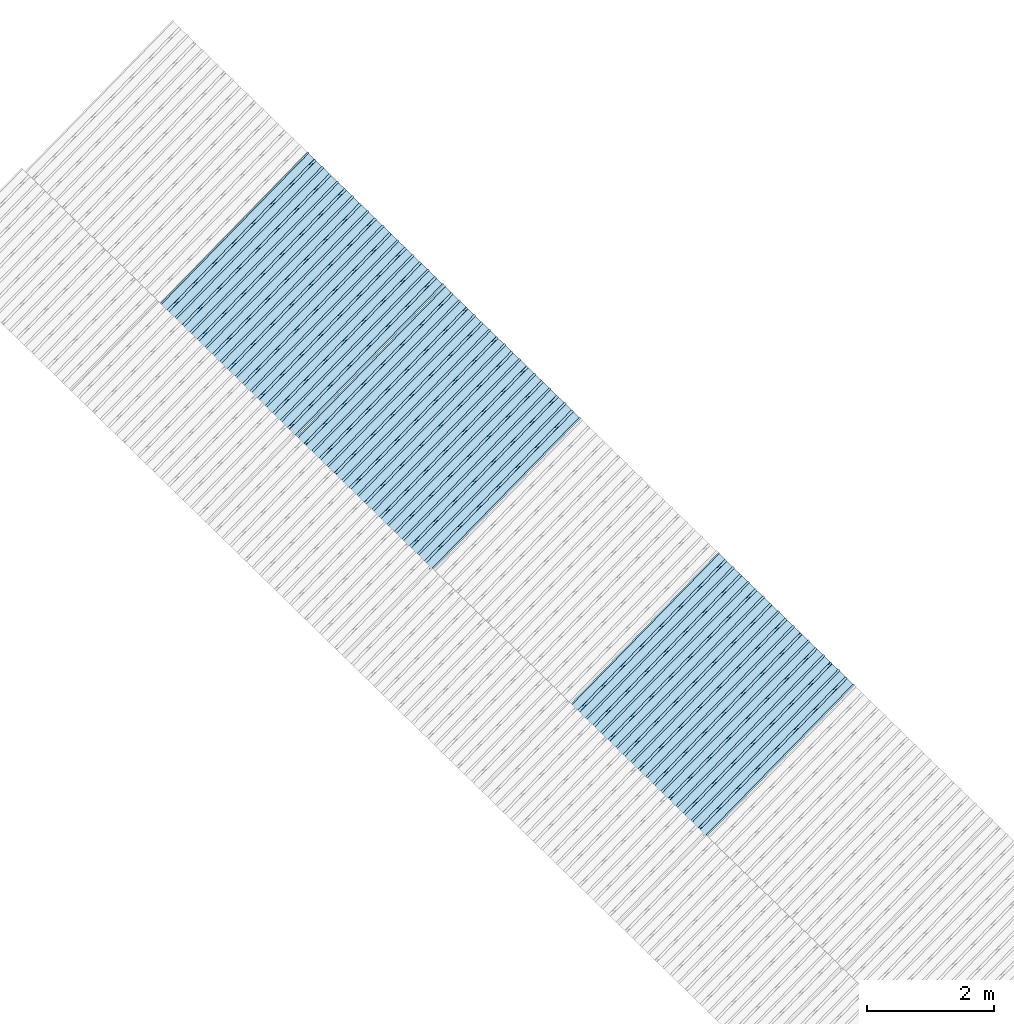
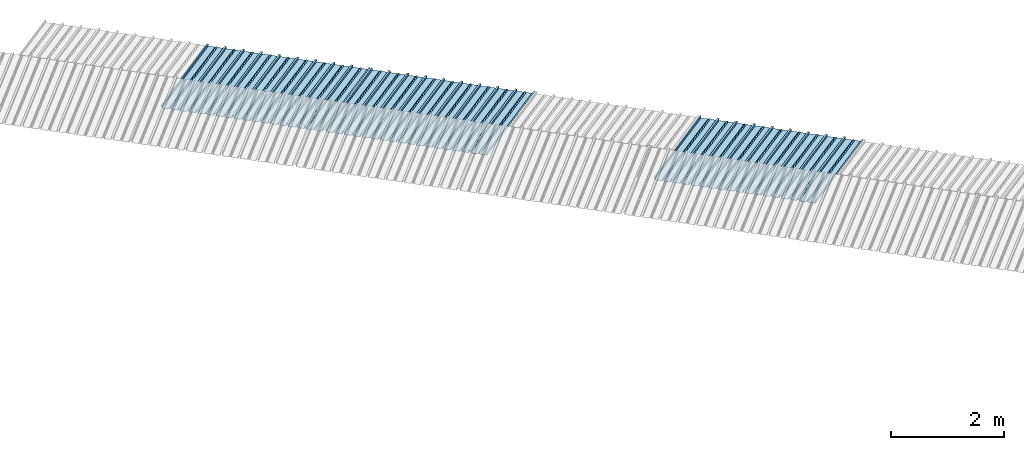
# One storey, part 7 of 8: 3 plates, 1 element without a shape of its own.
"""IFC4 building model written with IfcOpenShell, lengths in metres."""

from ifc_helpers import new_model, entity, si_unit, converted_unit, direction, frame, origin, place, context, subcontext, project, spatial, line, arc, indexed_curve, outline, extrude, source, transform, mapped, material, type_object, type_shapes, element, aggregate, save


model = new_model("IFC4")

# Units and contexts
model_context = context("Model", 3, precision=1e-05, world=origin(), true_north=direction((6.123233995736766e-17, 1.0)))
body_context = subcontext(model_context, "Body", "Model", "MODEL_VIEW")
ifc_project = project(units=[si_unit("LENGTHUNIT", "METRE"), si_unit("AREAUNIT", "SQUARE_METRE"), si_unit("VOLUMEUNIT", "CUBIC_METRE"), converted_unit("PLANEANGLEUNIT", "DEGREE", entity("IfcPlaneAngleMeasure", 0.017453292519943278), si_unit("PLANEANGLEUNIT", "RADIAN"), dimensions=[0, 0, 0, 0, 0, 0, 0])], contexts=[model_context])

# Site, building, storey
site_placement = place(None, frame((0.0, 0.0, 0.0), z_axis=(0.0, 0.0, 1.0), x_axis=(0.7160934825303189, -0.6980043870045516, 0.0)))
site = spatial("IfcSite", under=ifc_project, at=site_placement, CompositionType="ELEMENT")
building_placement = place(site_placement, origin())
building = spatial("IfcBuilding", under=site, at=building_placement, CompositionType="ELEMENT")
storey_placement = place(building_placement, frame((0.0, 0.0, -1.24)))
storey = spatial("IfcBuildingStorey", under=building, at=storey_placement, Name="Livello 5", CompositionType="ELEMENT", Elevation=-1.24)

# Roof, plates
curtain_wall_type = type_object("IfcCurtainWallType", Name="Vetrata Copertura 2", PredefinedType="NOTDEFINED")
roof_placement = place(storey_placement, frame((0.0, 0.0, 1.24)))
roof = element("IfcRoof", 1, at=roof_placement, inside=storey, type_object=curtain_wall_type, Name="Vetrata Copertura 2", ObjectType="Vetrata Copertura 2", PredefinedType="SHED_ROOF")
ifc_material = material(Name="Default")
plate_type_1 = type_object("IfcPlateType", Name="Pannello copertura:Pannello copertura", PredefinedType="CURTAIN_PANEL", material=ifc_material)
shared_shape_1 = source(origin(), body_context, "Body", "SweptSolid", [
    extrude(outline(indexed_curve([(1.339910560042256, -0.015785714285718594), (1.4699105600422562, -0.015785714285719003), (1.4699105600422562, 0.024214285714281004), (1.494919197675959, 0.02421428571428092), (1.494919197675959, 0.027214285714280917), (1.466910560042256, 0.027214285714281014), (1.466910560042256, -0.012785714285718995), (1.3417510978483753, -0.012785714285718492), (1.3199105600422556, 4.9134324369942785e-05), (1.2980700222361363, -0.012785714285718328), (1.1729105600422558, -0.01278571428571804), (1.1729105600422558, 0.02721428571428197), (1.136910560042256, 0.027214285714282097), (1.136910560042256, -0.012785714285717937), (1.0117510978483748, -0.01278571428571754), (0.9899105600422554, 4.913432437100935e-05), (0.968070022236136, -0.01278571428571726), (0.8429105600422558, -0.012785714285716971), (0.842910560042256, 0.027214285714283023), (0.8069105600422554, 0.027214285714283144), (0.8069105600422554, -0.01278571428571687), (0.6817510978483748, -0.012785714285716475), (0.6599105600422555, 4.9134324372075926e-05), (0.6380700222361361, -0.012785714285716196), (0.5129105600422553, -0.012785714285715915), (0.5129105600422554, 0.027214285714284105), (0.47691056004225557, 0.027214285714284227), (0.47691056004225557, -0.012785714285715804), (0.3517510978483749, -0.012785714285715427), (0.32991056004225544, 4.9134324373142496e-05), (0.3080700222361361, -0.012785714285715127), (0.18291056004225528, -0.012785714285714848), (0.18291056004225553, 0.027214285714285157), (0.1469105600422553, 0.02721428571428528), (0.14691056004225533, -0.012785714285714738), (0.021751097848374697, -0.01278571428571434), (-8.943995774469983e-05, 4.913432437420907e-05), (-0.021929977763864118, -0.01278571428571406), (-0.1470894399577447, -0.012785714285713783), (-0.14708943995774473, 0.02721428571428624), (-0.18308943995774493, 0.027214285714286364), (-0.1830894399577449, -0.012785714285713672), (-0.30824890215162537, -0.012785714285713215), (-0.33008943995774487, 4.9134324375275644e-05), (-0.3519299777638641, -0.012785714285712995), (-0.47708943995774494, -0.012785714285712714), (-0.4770894399577447, 0.02721428571428729), (-0.5130894399577449, 0.02721428571428741), (-0.5130894399577449, -0.012785714285712603), (-0.6382489021516256, -0.012785714285712207), (-0.6600894399577448, 4.9134324376342214e-05), (-0.6819299777638644, -0.012785714285711926), (-0.8070894399577453, -0.012785714285711647), (-0.807089439957745, 0.027214285714288373), (-0.843089439957745, 0.027214285714288494), (-0.8430894399577447, -0.012785714285711538), (-0.968248902151626, -0.012785714285711083), (-0.9900894399577453, 4.9134324377408785e-05), (-1.0119299777638646, -0.012785714285710861), (-1.1370894399577456, -0.012785714285710582), (-1.1370894399577451, 0.02721428571428942), (-1.1730894399577452, 0.027214285714289545), (-1.1730894399577454, -0.012785714285710473), (-1.2982489021516257, -0.012785714285710093), (-1.3200894399577452, 4.9134324378475355e-05), (-1.3419299777638647, -0.012785714285709794), (-1.4670894399577457, -0.012785714285709513), (-1.4670894399577454, 0.027214285714290503), (-1.490089439957745, 0.027214285714290586), (-1.490089439957745, 0.024214285714290556), (-1.4700894399577447, 0.02421428571429049), (-1.4700894399577449, -0.015785714285709514), (-1.3400894399577452, -0.015785714285709924), (-1.3200894399577452, -0.0029508656756215236), (-1.3000894399577452, -0.015785714285710063), (-1.170089439957745, -0.015785714285710472), (-1.1700894399577453, 0.024214285714289543), (-1.140089439957745, 0.02421428571428944), (-1.1400894399577455, -0.015785714285710583), (-1.0100894399577454, -0.015785714285710992), (-0.9900894399577453, -0.00295086567562259), (-0.9700894399577453, -0.015785714285711128), (-0.8400894399577448, -0.01578571428571154), (-0.8400894399577451, 0.024214285714288453), (-0.8100894399577452, 0.024214285714288356), (-0.8100894399577452, -0.015785714285711648), (-0.6800894399577451, -0.015785714285712012), (-0.6600894399577448, -0.0029508656756236573), (-0.6400894399577448, -0.015785714285712196), (-0.5100894399577451, -0.015785714285712606), (-0.5100894399577451, 0.024214285714287406), (-0.4800894399577449, 0.024214285714287305), (-0.4800894399577449, -0.015785714285712713), (-0.350089439957745, -0.01578571428571316), (-0.33008943995774487, -0.0029508656756247237), (-0.31008943995774485, -0.01578571428571326), (-0.1800894399577448, -0.015785714285713674), (-0.1800894399577448, 0.024214285714286323), (-0.1500894399577446, 0.02421428571428622), (-0.15008943995774485, -0.015785714285713782), (-0.020089439957744877, -0.015785714285714264), (-8.943995774473269e-05, -0.00295086567562579), (0.01991056004225521, -0.015785714285714323), (0.14991056004225545, -0.01578571428571474), (0.14991056004225542, 0.024214285714285272), (0.17991056004225567, 0.02421428571428517), (0.1799105600422554, -0.01578571428571485), (0.30991056004225526, -0.01578571428571532), (0.32991056004225544, -0.0029508656756268565), (0.3499105600422554, -0.015785714285715395), (0.47991056004225535, -0.015785714285715804), (0.47991056004225535, 0.02421428571428419), (0.5099105600422553, 0.02421428571428409), (0.5099105600422552, -0.015785714285715916), (0.6399105600422554, -0.015785714285716325), (0.6599105600422555, -0.002950865675627923), (0.6799105600422555, -0.01578571428571646), (0.8099105600422557, -0.015785714285716873), (0.8099105600422557, 0.02421428571428314), (0.8399105600422555, 0.02421428571428304), (0.8399105600422554, -0.015785714285716974), (0.9699105600422554, -0.015785714285717393), (0.9899105600422554, -0.0029508656756289894), (1.0099105600422555, -0.01578571428571753), (1.1399105600422557, -0.015785714285717938), (1.1399105600422557, 0.024214285714282077), (1.169910560042256, 0.024214285714281972), (1.1699105600422557, -0.01578571428571804), (1.2999105600422558, -0.01578571428571846), (1.3199105600422558, -0.0029508656756300567)], segments=[line(1, 2, 3, 4, 5, 6, 7, 8), arc(8, 9, 10), line(10, 11, 12, 13, 14, 15), arc(15, 16, 17), line(17, 18, 19, 20, 21, 22), arc(22, 23, 24), line(24, 25, 26, 27, 28, 29), arc(29, 30, 31), line(31, 32, 33, 34, 35, 36), arc(36, 37, 38), line(38, 39, 40, 41, 42, 43), arc(43, 44, 45), line(45, 46, 47, 48, 49, 50), arc(50, 51, 52), line(52, 53, 54, 55, 56, 57), arc(57, 58, 59), line(59, 60, 61, 62, 63, 64), arc(64, 65, 66), line(66, 67, 68, 69, 70, 71, 72, 73), arc(73, 74, 75), line(75, 76, 77, 78, 79, 80), arc(80, 81, 82), line(82, 83, 84, 85, 86, 87), arc(87, 88, 89), line(89, 90, 91, 92, 93, 94), arc(94, 95, 96), line(96, 97, 98, 99, 100, 101), arc(101, 102, 103), line(103, 104, 105, 106, 107, 108), arc(108, 109, 110), line(110, 111, 112, 113, 114, 115), arc(115, 116, 117), line(117, 118, 119, 120, 121, 122), arc(122, 123, 124), line(124, 125, 126, 127, 128, 129), arc(129, 130, 1)], self_intersect=False)), frame((8.080232403624576e-05, -0.015785714285719014, 0.0), z_axis=(0.0, 0.0, -1.0), x_axis=(1.0, 0.0, 0.0)), (0.0, 0.0, -1.0), 3.472878469300717),
])
type_shapes(plate_type_1, [shared_shape_1])
plate_1_placement = place(roof_placement, frame((-23.174876898450716, -4.997561216564662, -1.6240000000000003), z_axis=(0.0, 0.9632563788424056, -0.26858359707810914), x_axis=(1.0, 0.0, 0.0)))
plate_1 = element("IfcPlate", 2, at=plate_1_placement, type_object=plate_type_1, material=ifc_material, Name="Pannello copertura:Pannello copertura", ObjectType="Pannello copertura:Pannello copertura", PredefinedType="CURTAIN_PANEL", context=body_context, shape_type="MappedRepresentation", body=[
    mapped(shared_shape_1, transform((0.0, 0.0, 0.0), scale=1.0)),
])
plate_type_2 = type_object("IfcPlateType", Name="Pannello copertura:Pannello copertura", PredefinedType="CURTAIN_PANEL", material=ifc_material)
shared_shape_2 = source(origin(), body_context, "Body", "SweptSolid", [
    extrude(outline(indexed_curve([(1.339910560042256, -0.015785714285718594), (1.4699105600422562, -0.015785714285719003), (1.4699105600422562, 0.024214285714281004), (1.494919197675959, 0.02421428571428092), (1.494919197675959, 0.027214285714280917), (1.466910560042256, 0.027214285714281014), (1.466910560042256, -0.012785714285718995), (1.3417510978483753, -0.012785714285718492), (1.3199105600422556, 4.9134324369942785e-05), (1.2980700222361363, -0.012785714285718328), (1.1729105600422558, -0.01278571428571804), (1.1729105600422558, 0.02721428571428197), (1.136910560042256, 0.027214285714282097), (1.136910560042256, -0.012785714285717937), (1.0117510978483748, -0.01278571428571754), (0.9899105600422554, 4.913432437100935e-05), (0.968070022236136, -0.01278571428571726), (0.8429105600422558, -0.012785714285716971), (0.842910560042256, 0.027214285714283023), (0.8069105600422554, 0.027214285714283144), (0.8069105600422554, -0.01278571428571687), (0.6817510978483748, -0.012785714285716475), (0.6599105600422555, 4.9134324372075926e-05), (0.6380700222361361, -0.012785714285716196), (0.5129105600422553, -0.012785714285715915), (0.5129105600422554, 0.027214285714284105), (0.47691056004225557, 0.027214285714284227), (0.47691056004225557, -0.012785714285715804), (0.3517510978483749, -0.012785714285715427), (0.32991056004225544, 4.9134324373142496e-05), (0.3080700222361361, -0.012785714285715127), (0.18291056004225528, -0.012785714285714848), (0.18291056004225553, 0.027214285714285157), (0.1469105600422553, 0.02721428571428528), (0.14691056004225533, -0.012785714285714738), (0.021751097848374697, -0.01278571428571434), (-8.943995774469983e-05, 4.913432437420907e-05), (-0.021929977763864118, -0.01278571428571406), (-0.1470894399577447, -0.012785714285713783), (-0.14708943995774473, 0.02721428571428624), (-0.18308943995774493, 0.027214285714286364), (-0.1830894399577449, -0.012785714285713672), (-0.30824890215162537, -0.012785714285713215), (-0.33008943995774487, 4.9134324375275644e-05), (-0.3519299777638641, -0.012785714285712995), (-0.47708943995774494, -0.012785714285712714), (-0.4770894399577447, 0.02721428571428729), (-0.5130894399577449, 0.02721428571428741), (-0.5130894399577449, -0.012785714285712603), (-0.6382489021516256, -0.012785714285712207), (-0.6600894399577448, 4.9134324376342214e-05), (-0.6819299777638644, -0.012785714285711926), (-0.8070894399577453, -0.012785714285711647), (-0.807089439957745, 0.027214285714288373), (-0.843089439957745, 0.027214285714288494), (-0.8430894399577447, -0.012785714285711538), (-0.968248902151626, -0.012785714285711083), (-0.9900894399577453, 4.9134324377408785e-05), (-1.0119299777638646, -0.012785714285710861), (-1.1370894399577456, -0.012785714285710582), (-1.1370894399577451, 0.02721428571428942), (-1.1730894399577452, 0.027214285714289545), (-1.1730894399577454, -0.012785714285710473), (-1.2982489021516257, -0.012785714285710093), (-1.3200894399577452, 4.9134324378475355e-05), (-1.3419299777638647, -0.012785714285709794), (-1.4670894399577457, -0.012785714285709513), (-1.4670894399577454, 0.027214285714290503), (-1.490089439957745, 0.027214285714290586), (-1.490089439957745, 0.024214285714290556), (-1.4700894399577447, 0.02421428571429049), (-1.4700894399577449, -0.015785714285709514), (-1.3400894399577452, -0.015785714285709924), (-1.3200894399577452, -0.0029508656756215236), (-1.3000894399577452, -0.015785714285710063), (-1.170089439957745, -0.015785714285710472), (-1.1700894399577453, 0.024214285714289543), (-1.140089439957745, 0.02421428571428944), (-1.1400894399577455, -0.015785714285710583), (-1.0100894399577454, -0.015785714285710992), (-0.9900894399577453, -0.00295086567562259), (-0.9700894399577453, -0.015785714285711128), (-0.8400894399577448, -0.01578571428571154), (-0.8400894399577451, 0.024214285714288453), (-0.8100894399577452, 0.024214285714288356), (-0.8100894399577452, -0.015785714285711648), (-0.6800894399577451, -0.015785714285712012), (-0.6600894399577448, -0.0029508656756236573), (-0.6400894399577448, -0.015785714285712196), (-0.5100894399577451, -0.015785714285712606), (-0.5100894399577451, 0.024214285714287406), (-0.4800894399577449, 0.024214285714287305), (-0.4800894399577449, -0.015785714285712713), (-0.350089439957745, -0.01578571428571316), (-0.33008943995774487, -0.0029508656756247237), (-0.31008943995774485, -0.01578571428571326), (-0.1800894399577448, -0.015785714285713674), (-0.1800894399577448, 0.024214285714286323), (-0.1500894399577446, 0.02421428571428622), (-0.15008943995774485, -0.015785714285713782), (-0.020089439957744877, -0.015785714285714264), (-8.943995774473269e-05, -0.00295086567562579), (0.01991056004225521, -0.015785714285714323), (0.14991056004225545, -0.01578571428571474), (0.14991056004225542, 0.024214285714285272), (0.17991056004225567, 0.02421428571428517), (0.1799105600422554, -0.01578571428571485), (0.30991056004225526, -0.01578571428571532), (0.32991056004225544, -0.0029508656756268565), (0.3499105600422554, -0.015785714285715395), (0.47991056004225535, -0.015785714285715804), (0.47991056004225535, 0.02421428571428419), (0.5099105600422553, 0.02421428571428409), (0.5099105600422552, -0.015785714285715916), (0.6399105600422554, -0.015785714285716325), (0.6599105600422555, -0.002950865675627923), (0.6799105600422555, -0.01578571428571646), (0.8099105600422557, -0.015785714285716873), (0.8099105600422557, 0.02421428571428314), (0.8399105600422555, 0.02421428571428304), (0.8399105600422554, -0.015785714285716974), (0.9699105600422554, -0.015785714285717393), (0.9899105600422554, -0.0029508656756289894), (1.0099105600422555, -0.01578571428571753), (1.1399105600422557, -0.015785714285717938), (1.1399105600422557, 0.024214285714282077), (1.169910560042256, 0.024214285714281972), (1.1699105600422557, -0.01578571428571804), (1.2999105600422558, -0.01578571428571846), (1.3199105600422558, -0.0029508656756300567)], segments=[line(1, 2, 3, 4, 5, 6, 7, 8), arc(8, 9, 10), line(10, 11, 12, 13, 14, 15), arc(15, 16, 17), line(17, 18, 19, 20, 21, 22), arc(22, 23, 24), line(24, 25, 26, 27, 28, 29), arc(29, 30, 31), line(31, 32, 33, 34, 35, 36), arc(36, 37, 38), line(38, 39, 40, 41, 42, 43), arc(43, 44, 45), line(45, 46, 47, 48, 49, 50), arc(50, 51, 52), line(52, 53, 54, 55, 56, 57), arc(57, 58, 59), line(59, 60, 61, 62, 63, 64), arc(64, 65, 66), line(66, 67, 68, 69, 70, 71, 72, 73), arc(73, 74, 75), line(75, 76, 77, 78, 79, 80), arc(80, 81, 82), line(82, 83, 84, 85, 86, 87), arc(87, 88, 89), line(89, 90, 91, 92, 93, 94), arc(94, 95, 96), line(96, 97, 98, 99, 100, 101), arc(101, 102, 103), line(103, 104, 105, 106, 107, 108), arc(108, 109, 110), line(110, 111, 112, 113, 114, 115), arc(115, 116, 117), line(117, 118, 119, 120, 121, 122), arc(122, 123, 124), line(124, 125, 126, 127, 128, 129), arc(129, 130, 1)], self_intersect=False)), frame((8.080232403624576e-05, -0.015785714285719014, 0.0), z_axis=(0.0, 0.0, -1.0), x_axis=(1.0, 0.0, 0.0)), (0.0, 0.0, -1.0), 3.472878469300717),
])
type_shapes(plate_type_2, [shared_shape_2])
plate_2_placement = place(roof_placement, frame((-20.174871829776173, -4.997561216564662, -1.6240000000000003), z_axis=(0.0, 0.9632563788424056, -0.26858359707810914), x_axis=(1.0, 0.0, 0.0)))
plate_2 = element("IfcPlate", 3, at=plate_2_placement, type_object=plate_type_2, material=ifc_material, Name="Pannello copertura:Pannello copertura", ObjectType="Pannello copertura:Pannello copertura", PredefinedType="CURTAIN_PANEL", context=body_context, shape_type="MappedRepresentation", body=[
    mapped(shared_shape_2, transform((0.0, 0.0, 0.0), scale=1.0)),
])
plate_type_3 = type_object("IfcPlateType", Name="Pannello copertura:Pannello copertura", PredefinedType="CURTAIN_PANEL", material=ifc_material)
shared_shape_3 = source(origin(), body_context, "Body", "SweptSolid", [
    extrude(outline(indexed_curve([(1.339910560042256, -0.015785714285718594), (1.4699105600422562, -0.015785714285719003), (1.4699105600422562, 0.024214285714281004), (1.494919197675959, 0.02421428571428092), (1.494919197675959, 0.027214285714280917), (1.466910560042256, 0.027214285714281014), (1.466910560042256, -0.012785714285718995), (1.3417510978483753, -0.012785714285718492), (1.3199105600422556, 4.9134324369942785e-05), (1.2980700222361363, -0.012785714285718328), (1.1729105600422558, -0.01278571428571804), (1.1729105600422558, 0.02721428571428197), (1.136910560042256, 0.027214285714282097), (1.136910560042256, -0.012785714285717937), (1.0117510978483748, -0.01278571428571754), (0.9899105600422554, 4.913432437100935e-05), (0.968070022236136, -0.01278571428571726), (0.8429105600422558, -0.012785714285716971), (0.842910560042256, 0.027214285714283023), (0.8069105600422554, 0.027214285714283144), (0.8069105600422554, -0.01278571428571687), (0.6817510978483748, -0.012785714285716475), (0.6599105600422555, 4.9134324372075926e-05), (0.6380700222361361, -0.012785714285716196), (0.5129105600422553, -0.012785714285715915), (0.5129105600422554, 0.027214285714284105), (0.47691056004225557, 0.027214285714284227), (0.47691056004225557, -0.012785714285715804), (0.3517510978483749, -0.012785714285715427), (0.32991056004225544, 4.9134324373142496e-05), (0.3080700222361361, -0.012785714285715127), (0.18291056004225528, -0.012785714285714848), (0.18291056004225553, 0.027214285714285157), (0.1469105600422553, 0.02721428571428528), (0.14691056004225533, -0.012785714285714738), (0.021751097848374697, -0.01278571428571434), (-8.943995774469983e-05, 4.913432437420907e-05), (-0.021929977763864118, -0.01278571428571406), (-0.1470894399577447, -0.012785714285713783), (-0.14708943995774473, 0.02721428571428624), (-0.18308943995774493, 0.027214285714286364), (-0.1830894399577449, -0.012785714285713672), (-0.30824890215162537, -0.012785714285713215), (-0.33008943995774487, 4.9134324375275644e-05), (-0.3519299777638641, -0.012785714285712995), (-0.47708943995774494, -0.012785714285712714), (-0.4770894399577447, 0.02721428571428729), (-0.5130894399577449, 0.02721428571428741), (-0.5130894399577449, -0.012785714285712603), (-0.6382489021516256, -0.012785714285712207), (-0.6600894399577448, 4.9134324376342214e-05), (-0.6819299777638644, -0.012785714285711926), (-0.8070894399577453, -0.012785714285711647), (-0.807089439957745, 0.027214285714288373), (-0.843089439957745, 0.027214285714288494), (-0.8430894399577447, -0.012785714285711538), (-0.968248902151626, -0.012785714285711083), (-0.9900894399577453, 4.9134324377408785e-05), (-1.0119299777638646, -0.012785714285710861), (-1.1370894399577456, -0.012785714285710582), (-1.1370894399577451, 0.02721428571428942), (-1.1730894399577452, 0.027214285714289545), (-1.1730894399577454, -0.012785714285710473), (-1.2982489021516257, -0.012785714285710093), (-1.3200894399577452, 4.9134324378475355e-05), (-1.3419299777638647, -0.012785714285709794), (-1.4670894399577457, -0.012785714285709513), (-1.4670894399577454, 0.027214285714290503), (-1.490089439957745, 0.027214285714290586), (-1.490089439957745, 0.024214285714290556), (-1.4700894399577447, 0.02421428571429049), (-1.4700894399577449, -0.015785714285709514), (-1.3400894399577452, -0.015785714285709924), (-1.3200894399577452, -0.0029508656756215236), (-1.3000894399577452, -0.015785714285710063), (-1.170089439957745, -0.015785714285710472), (-1.1700894399577453, 0.024214285714289543), (-1.140089439957745, 0.02421428571428944), (-1.1400894399577455, -0.015785714285710583), (-1.0100894399577454, -0.015785714285710992), (-0.9900894399577453, -0.00295086567562259), (-0.9700894399577453, -0.015785714285711128), (-0.8400894399577448, -0.01578571428571154), (-0.8400894399577451, 0.024214285714288453), (-0.8100894399577452, 0.024214285714288356), (-0.8100894399577452, -0.015785714285711648), (-0.6800894399577451, -0.015785714285712012), (-0.6600894399577448, -0.0029508656756236573), (-0.6400894399577448, -0.015785714285712196), (-0.5100894399577451, -0.015785714285712606), (-0.5100894399577451, 0.024214285714287406), (-0.4800894399577449, 0.024214285714287305), (-0.4800894399577449, -0.015785714285712713), (-0.350089439957745, -0.01578571428571316), (-0.33008943995774487, -0.0029508656756247237), (-0.31008943995774485, -0.01578571428571326), (-0.1800894399577448, -0.015785714285713674), (-0.1800894399577448, 0.024214285714286323), (-0.1500894399577446, 0.02421428571428622), (-0.15008943995774485, -0.015785714285713782), (-0.020089439957744877, -0.015785714285714264), (-8.943995774473269e-05, -0.00295086567562579), (0.01991056004225521, -0.015785714285714323), (0.14991056004225545, -0.01578571428571474), (0.14991056004225542, 0.024214285714285272), (0.17991056004225567, 0.02421428571428517), (0.1799105600422554, -0.01578571428571485), (0.30991056004225526, -0.01578571428571532), (0.32991056004225544, -0.0029508656756268565), (0.3499105600422554, -0.015785714285715395), (0.47991056004225535, -0.015785714285715804), (0.47991056004225535, 0.02421428571428419), (0.5099105600422553, 0.02421428571428409), (0.5099105600422552, -0.015785714285715916), (0.6399105600422554, -0.015785714285716325), (0.6599105600422555, -0.002950865675627923), (0.6799105600422555, -0.01578571428571646), (0.8099105600422557, -0.015785714285716873), (0.8099105600422557, 0.02421428571428314), (0.8399105600422555, 0.02421428571428304), (0.8399105600422554, -0.015785714285716974), (0.9699105600422554, -0.015785714285717393), (0.9899105600422554, -0.0029508656756289894), (1.0099105600422555, -0.01578571428571753), (1.1399105600422557, -0.015785714285717938), (1.1399105600422557, 0.024214285714282077), (1.169910560042256, 0.024214285714281972), (1.1699105600422557, -0.01578571428571804), (1.2999105600422558, -0.01578571428571846), (1.3199105600422558, -0.0029508656756300567)], segments=[line(1, 2, 3, 4, 5, 6, 7, 8), arc(8, 9, 10), line(10, 11, 12, 13, 14, 15), arc(15, 16, 17), line(17, 18, 19, 20, 21, 22), arc(22, 23, 24), line(24, 25, 26, 27, 28, 29), arc(29, 30, 31), line(31, 32, 33, 34, 35, 36), arc(36, 37, 38), line(38, 39, 40, 41, 42, 43), arc(43, 44, 45), line(45, 46, 47, 48, 49, 50), arc(50, 51, 52), line(52, 53, 54, 55, 56, 57), arc(57, 58, 59), line(59, 60, 61, 62, 63, 64), arc(64, 65, 66), line(66, 67, 68, 69, 70, 71, 72, 73), arc(73, 74, 75), line(75, 76, 77, 78, 79, 80), arc(80, 81, 82), line(82, 83, 84, 85, 86, 87), arc(87, 88, 89), line(89, 90, 91, 92, 93, 94), arc(94, 95, 96), line(96, 97, 98, 99, 100, 101), arc(101, 102, 103), line(103, 104, 105, 106, 107, 108), arc(108, 109, 110), line(110, 111, 112, 113, 114, 115), arc(115, 116, 117), line(117, 118, 119, 120, 121, 122), arc(122, 123, 124), line(124, 125, 126, 127, 128, 129), arc(129, 130, 1)], self_intersect=False)), frame((8.080232403624576e-05, -0.015785714285719014, 0.0), z_axis=(0.0, 0.0, -1.0), x_axis=(1.0, 0.0, 0.0)), (0.0, 0.0, -1.0), 3.472878469300717),
])
type_shapes(plate_type_3, [shared_shape_3])
plate_3_placement = place(roof_placement, frame((-14.174862552739624, -4.997561216564662, -1.6240000000000003), z_axis=(0.0, 0.9632563788424056, -0.26858359707810914), x_axis=(1.0, 0.0, 0.0)))
plate_3 = element("IfcPlate", 4, at=plate_3_placement, type_object=plate_type_3, material=ifc_material, Name="Pannello copertura:Pannello copertura", ObjectType="Pannello copertura:Pannello copertura", PredefinedType="CURTAIN_PANEL", context=body_context, shape_type="MappedRepresentation", body=[
    mapped(shared_shape_3, transform((0.0, 0.0, 0.0), scale=1.0)),
])
aggregate(roof, [plate_1, plate_2, plate_3])

save(model, "model.ifc")
